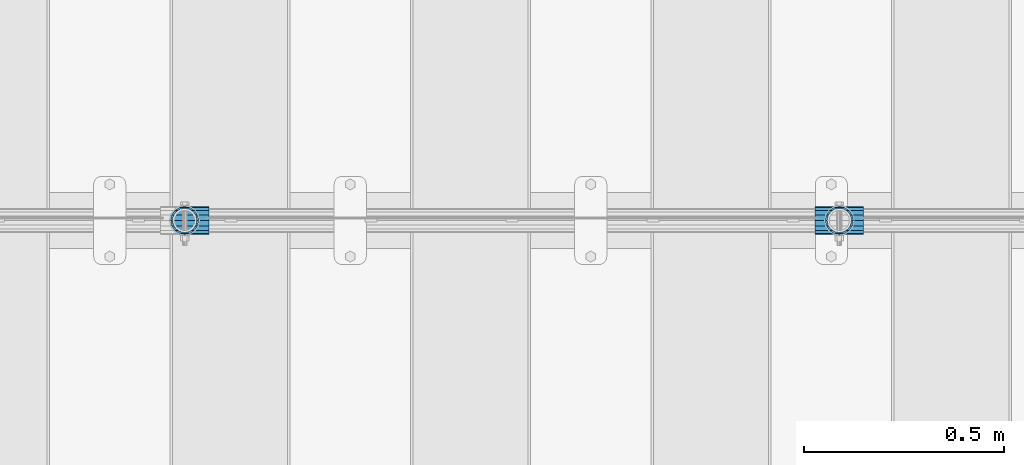
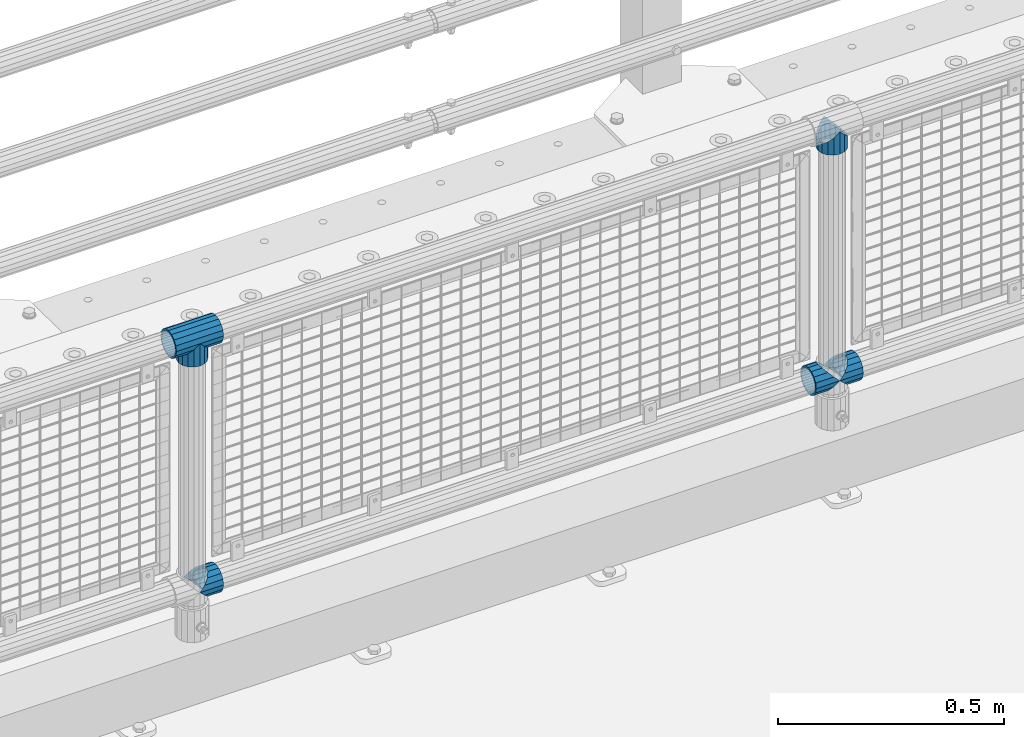
# One storey, part 164 of 270: 6 beams.
"""IFC2X3 building model written with IfcOpenShell, lengths in millimetres."""

from ifc_helpers import new_model, si_unit, frame, origin_with_axes, place, context, subcontext, project, spatial, faceted_brep, material, type_object, element, save


model = new_model("IFC2X3")

# Units and contexts
model_context = context("Model", 3, precision=1e-05, world=origin_with_axes())
body_context = subcontext(model_context, "Body", "Model", "MODEL_VIEW")
ifc_project = project(units=[si_unit("LENGTHUNIT", "METRE", prefix="MILLI"), si_unit("AREAUNIT", "SQUARE_METRE"), si_unit("VOLUMEUNIT", "CUBIC_METRE"), si_unit("MASSUNIT", "GRAM", prefix="KILO"), si_unit("TIMEUNIT", "SECOND"), si_unit("PLANEANGLEUNIT", "RADIAN"), si_unit("SOLIDANGLEUNIT", "STERADIAN"), si_unit("THERMODYNAMICTEMPERATUREUNIT", "DEGREE_CELSIUS"), si_unit("LUMINOUSINTENSITYUNIT", "LUMEN")], contexts=[model_context])

# Site, building, storey
site_placement = place(None, origin_with_axes())
site = spatial("IfcSite", under=ifc_project, at=site_placement, CompositionType="ELEMENT")
building_placement = place(site_placement, origin_with_axes())
building = spatial("IfcBuilding", under=site, at=building_placement, Name="Standard", CompositionType="ELEMENT")
storey_placement = place(building_placement, origin_with_axes())
storey = spatial("IfcBuildingStorey", under=building, at=storey_placement, Name="Undefined", CompositionType="ELEMENT", Elevation=0.0)

# Beams
ifc_material = material(Name="Misc_Undefined")
beam_type = type_object("IfcBeamType", PredefinedType="NOTDEFINED")
beam_1_placement = place(storey_placement, frame((5459.85, -16335.5, 298.17), z_axis=(0.0, 1.0, 0.0), x_axis=(1.0, 0.0, 0.0)))
element("IfcBeam", 1, at=beam_1_placement, inside=storey, type_object=beam_type, material=ifc_material, context=body_context, shape_type="Brep", body=[
    faceted_brep([(60.1499999999978, 0.0, -35.1499999999996), (46.698677352364, 13.4513226476329, -32.4743655677721), (46.698677352364, -13.4513226476329, -32.4743655677721), (33.0273231408937, 21.4606908090117, 21.4606908090118), (27.6756344322275, 26.8123795176776, 13.4513226476338), (27.6756344322275, 32.4743655677717, 13.4513226476338), (35.2951966412911, 24.8548033587072, 24.8548033587067), (35.2951966412911, 16.3810424080045, 24.8548033587067), (27.310256188277, 28.0397438117175, 11.6144421722802), (24.9999999999964, 30.35, 0.0), (24.9999999999964, 35.15, 0.0), (27.6756344322275, 26.8123795176775, -13.4513226476338), (27.6756344322275, 32.4743655677717, -13.4513226476338), (27.310256188277, 28.0397438117175, -11.6144421722802), (35.2951966412911, 16.3810424080045, -24.8548033587067), (35.2951966412911, 24.8548033587072, -24.8548033587067), (33.0273231408937, 21.4606908090117, -21.4606908090118), (40.0617968770166, 11.6144421722805, -28.0397438117179), (43.519339601633, 0.0, -30.3500000000004), (40.0617968770166, -11.6144421722805, -28.0397438117179), (35.2951966412911, -16.3810424080045, -24.8548033587067), (35.2951966412911, -24.8548033587072, -24.8548033587067), (33.0273231408937, -21.4606908090117, -21.4606908090118), (27.6756344322275, -26.8123795176776, -13.4513226476338), (27.6756344322275, -32.4743655677717, -13.4513226476338), (27.310256188277, -28.0397438117175, -11.6144421722802), (24.9999999999964, -30.35, 0.0), (24.9999999999964, -35.15, 0.0), (27.310256188277, -28.0397438117175, 11.6144421722802), (27.6756344322275, -26.8123795176775, 13.4513226476338), (27.6756344322275, -32.4743655677717, 13.4513226476338), (33.0273231408937, -21.4606908090117, 21.4606908090118), (35.2951966412911, -16.3810424080078, 24.8548033587067), (35.2951966412911, -24.8548033587072, 24.8548033587067), (60.1499999999978, 0.0, 35.1499999999996), (46.698677352364, -13.4513226476329, 32.4743655677721), (46.698677352364, 13.4513226476329, 32.4743655677721), (40.061796877013, -11.6144421722805, 28.0397438117179), (43.5193396016293, 0.0, 30.3500000000004), (40.061796877013, 11.6144421722805, 28.0397438117179), (0.0, -32.4743655677721, -13.4513226476338), (0.0, -24.8548033587067, -24.8548033587067), (0.0, -13.4513226476338, -32.4743655677703), (0.0, 0.0, -35.1499999999996), (0.0, 13.4513226476338, -32.4743655677703), (0.0, 24.8548033587067, -24.8548033587067), (0.0, 32.4743655677721, -13.4513226476338), (0.0, 35.1499999999996, 0.0), (0.0, 32.4743655677721, 13.4513226476338), (0.0, 24.8548033587067, 24.8548033587067), (0.0, 13.4513226476338, 32.4743655677703), (0.0, 0.0, 35.1499999999996), (0.0, -32.4743655677721, 13.4513226476338), (0.0, -35.1499999999996, 0.0), (0.0, -24.8548033587067, 24.8548033587067), (0.0, -13.4513226476338, 32.4743655677703), (0.0, -28.0397438117179, -11.614442172282), (0.0, -21.4606908090118, -21.46069080901), (0.0, -11.6144421722802, -28.0397438117179), (0.0, 0.0, -30.3499999999985), (0.0, 11.6144421722802, -28.0397438117179), (0.0, 21.4606908090118, -21.46069080901), (0.0, 28.0397438117179, -11.614442172282), (0.0, 30.3500000000004, 0.0), (0.0, 28.0397438117179, 11.614442172282), (0.0, 21.4606908090118, 21.46069080901), (0.0, 11.6144421722802, 28.0397438117179), (0.0, 0.0, 30.3499999999985), (0.0, -11.6144421722802, 28.0397438117179), (0.0, -21.4606908090118, 21.46069080901), (0.0, -28.0397438117179, 11.614442172282), (0.0, -30.3500000000004, 0.0)], [[[0, 1, 2]], [[3, 4, 5, 6, 7]], [[8, 9, 10, 5, 4]], [[11, 12, 10, 9, 13]], [[14, 15, 12, 11, 16]], [[2, 1, 15, 14, 17, 18, 19, 20, 21]], [[21, 20, 22, 23, 24]], [[24, 23, 25, 26, 27]], [[27, 26, 28, 29, 30]], [[30, 29, 31, 32, 33]], [[34, 35, 36]], [[33, 32, 37, 38, 39, 7, 6, 36, 35]], [[40, 41, 21, 24]], [[41, 42, 2, 21]], [[42, 43, 0, 2]], [[43, 44, 1, 0]], [[44, 45, 15, 1]], [[45, 46, 12, 15]], [[46, 47, 10, 12]], [[47, 48, 5, 10]], [[48, 49, 6, 5]], [[49, 50, 36, 6]], [[50, 51, 34, 36]], [[52, 53, 27, 30]], [[54, 52, 30, 33]], [[55, 54, 33, 35]], [[51, 55, 35, 34]], [[53, 40, 24, 27]], [[52, 54, 55, 51, 50, 49, 48, 47, 46, 45, 44, 43, 42, 41, 40, 53], [56, 57, 58, 59, 60, 61, 62, 63, 64, 65, 66, 67, 68, 69, 70, 71]], [[68, 67, 38, 37]], [[31, 69, 68, 37, 32]], [[28, 70, 69, 31, 29]], [[71, 70, 28, 26]], [[56, 71, 26, 25]], [[57, 56, 25, 23, 22]], [[58, 57, 22, 20, 19]], [[59, 58, 19, 18]], [[60, 59, 18, 17]], [[16, 61, 60, 17, 14]], [[13, 62, 61, 16, 11]], [[63, 62, 13, 9]], [[64, 63, 9, 8]], [[65, 64, 8, 4, 3]], [[66, 65, 3, 7, 39]], [[67, 66, 39, 38]]]),
])
beam_2_placement = place(storey_placement, frame((5520.0, -16335.5, 298.17), z_axis=(0.0, 1.0, 0.0), x_axis=(1.0, 0.0, 0.0)))
element("IfcBeam", 2, at=beam_2_placement, inside=storey, type_object=beam_type, material=ifc_material, context=body_context, shape_type="Brep", body=[
    faceted_brep([(13.4513226476338, 13.4513226476329, 32.4743655677721), (13.4513226476338, -13.4513226476329, 32.4743655677721), (0.0, 0.0, 35.1499999999996), (27.1226768591041, -21.4606908090117, -21.4606908090118), (24.8548033587067, -16.3810424080045, -24.8548033587067), (24.8548033587067, -24.8548033587072, -24.8548033587067), (32.4743655677703, -32.4743655677717, -13.4513226476338), (32.4743655677703, -26.8123795176776, -13.4513226476338), (0.0, 0.0, -35.1499999999996), (13.4513226476338, -13.4513226476329, -32.4743655677721), (13.4513226476338, 13.4513226476329, -32.4743655677721), (20.0882031229849, -11.6144421722805, -28.0397438117179), (16.6306603983721, 0.0, -30.3500000000004), (20.0882031229849, 11.6144421722805, -28.0397438117179), (24.8548033587067, 16.3810424080045, -24.8548033587067), (24.8548033587067, 24.8548033587072, -24.8548033587067), (27.1226768591041, 21.4606908090117, -21.4606908090118), (32.4743655677703, 26.8123795176775, -13.4513226476338), (32.4743655677703, 32.4743655677717, -13.4513226476338), (32.8397438117172, 28.0397438117175, -11.6144421722802), (35.1500000000015, 30.35, 0.0), (35.1500000000015, 35.1500000000003, 0.0), (32.8397438117208, 28.0397438117175, 11.6144421722802), (32.4743655677703, 26.8123795176776, 13.4513226476338), (32.4743655677703, 32.4743655677717, 13.4513226476338), (27.1226768591041, 21.4606908090117, 21.4606908090118), (24.8548033587067, 16.3810424080045, 24.8548033587067), (24.8548033587067, 24.8548033587072, 24.8548033587067), (20.0882031229812, 11.6144421722805, 28.0397438117179), (16.6306603983612, 0.0, 30.3500000000004), (20.0882031229812, -11.6144421722805, 28.0397438117179), (24.8548033587067, -16.3810424080045, 24.8548033587067), (24.8548033587067, -24.8548033587072, 24.8548033587067), (32.4743655677703, -26.8123795176775, 13.4513226476338), (32.4743655677703, -32.4743655677717, 13.4513226476338), (27.1226768591041, -21.4606908090117, 21.4606908090118), (35.1500000000015, -30.35, 0.0), (35.1500000000015, -35.15, 0.0), (32.8397438117208, -28.0397438117175, 11.6144421722802), (32.8397438117172, -28.0397438117175, -11.6144421722802), (60.1500000000015, -24.8548033587072, -24.8548033587067), (60.1500000000015, -32.4743655677717, -13.4513226476338), (60.1500000000015, -13.4513226476329, -32.4743655677721), (60.1499999999978, 0.0, -35.1499999999996), (60.1500000000015, 13.4513226476329, -32.4743655677721), (60.1500000000015, 24.8548033587072, -24.8548033587067), (60.1500000000015, 32.4743655677717, -13.4513226476338), (60.1500000000015, 35.15, 0.0), (60.1500000000015, 32.4743655677717, 13.4513226476338), (60.1500000000015, 24.8548033587072, 24.8548033587067), (60.1500000000015, 13.4513226476329, 32.4743655677721), (60.1499999999978, 0.0, 35.1499999999996), (60.1500000000015, -13.4513226476329, 32.4743655677721), (60.1500000000015, -24.8548033587072, 24.8548033587067), (60.1500000000015, -32.4743655677717, 13.4513226476338), (60.1500000000015, -35.15, 0.0), (60.1500000000015, -21.4606908090117, 21.4606908090118), (60.1500000000015, -11.6144421722805, 28.0397438117179), (60.1500000000015, 0.0, 30.3500000000004), (60.1500000000015, 11.6144421722805, 28.0397438117179), (60.1500000000015, 21.4606908090117, 21.4606908090118), (60.1500000000015, 28.0397438117175, 11.6144421722802), (60.1500000000015, 30.35, 0.0), (60.1500000000015, 28.0397438117175, -11.6144421722802), (60.1500000000015, 21.4606908090117, -21.4606908090118), (60.1500000000015, 11.6144421722805, -28.0397438117179), (60.1500000000015, 0.0, -30.3500000000004), (60.1500000000015, -11.6144421722805, -28.0397438117179), (60.1500000000015, -21.4606908090117, -21.4606908090118), (60.1500000000015, -28.0397438117175, -11.6144421722802), (60.1500000000015, -30.35, 0.0), (60.1500000000015, -28.0397438117175, 11.6144421722802)], [[[0, 1, 2]], [[3, 4, 5, 6, 7]], [[8, 9, 10]], [[10, 9, 5, 4, 11, 12, 13, 14, 15]], [[15, 14, 16, 17, 18]], [[18, 17, 19, 20, 21]], [[21, 20, 22, 23, 24]], [[24, 23, 25, 26, 27]], [[27, 26, 28, 29, 30, 31, 32, 1, 0]], [[33, 34, 32, 31, 35]], [[36, 37, 34, 33, 38]], [[39, 7, 6, 37, 36]], [[40, 41, 6, 5]], [[42, 40, 5, 9]], [[43, 42, 9, 8]], [[44, 43, 8, 10]], [[45, 44, 10, 15]], [[46, 45, 15, 18]], [[47, 46, 18, 21]], [[48, 47, 21, 24]], [[49, 48, 24, 27]], [[50, 49, 27, 0]], [[51, 50, 0, 2]], [[52, 51, 2, 1]], [[53, 52, 1, 32]], [[54, 53, 32, 34]], [[55, 54, 34, 37]], [[41, 55, 37, 6]], [[40, 42, 43, 44, 45, 46, 47, 48, 49, 50, 51, 52, 53, 54, 55, 41], [56, 57, 58, 59, 60, 61, 62, 63, 64, 65, 66, 67, 68, 69, 70, 71]], [[71, 70, 36, 38]], [[35, 56, 71, 38, 33]], [[30, 57, 56, 35, 31]], [[58, 57, 30, 29]], [[59, 58, 29, 28]], [[60, 59, 28, 26, 25]], [[61, 60, 25, 23, 22]], [[62, 61, 22, 20]], [[63, 62, 20, 19]], [[16, 64, 63, 19, 17]], [[13, 65, 64, 16, 14]], [[66, 65, 13, 12]], [[67, 66, 12, 11]], [[68, 67, 11, 4, 3]], [[69, 68, 3, 7, 39]], [[70, 69, 39, 36]]]),
])
beam_3_placement = place(storey_placement, frame((3887.0, -16335.5, 298.17), z_axis=(0.0, 1.0, 0.0), x_axis=(1.0, 0.0, 0.0)))
element("IfcBeam", 3, at=beam_3_placement, inside=storey, type_object=beam_type, material=ifc_material, context=body_context, shape_type="Brep", body=[
    faceted_brep([(13.4513226476338, 13.4513226476329, 32.4743655677721), (13.4513226476338, -13.4513226476329, 32.4743655677721), (0.0, 0.0, 35.1499999999996), (27.1226768591041, -21.4606908090117, -21.4606908090118), (24.8548033587067, -16.3810424080045, -24.8548033587067), (24.8548033587067, -24.8548033587072, -24.8548033587067), (32.4743655677703, -32.4743655677717, -13.4513226476338), (32.4743655677703, -26.8123795176776, -13.4513226476338), (0.0, 0.0, -35.1499999999996), (13.4513226476338, -13.4513226476329, -32.4743655677721), (13.4513226476338, 13.4513226476329, -32.4743655677721), (20.0882031229849, -11.6144421722805, -28.0397438117179), (16.6306603983721, 0.0, -30.3500000000004), (20.0882031229849, 11.6144421722805, -28.0397438117179), (24.8548033587067, 16.3810424080045, -24.8548033587067), (24.8548033587067, 24.8548033587072, -24.8548033587067), (27.1226768591041, 21.4606908090117, -21.4606908090118), (32.4743655677703, 26.8123795176775, -13.4513226476338), (32.4743655677703, 32.4743655677717, -13.4513226476338), (32.8397438117172, 28.0397438117175, -11.6144421722802), (35.1500000000015, 30.35, 0.0), (35.1500000000015, 35.1500000000003, 0.0), (32.8397438117208, 28.0397438117175, 11.6144421722802), (32.4743655677703, 26.8123795176776, 13.4513226476338), (32.4743655677703, 32.4743655677717, 13.4513226476338), (27.1226768591041, 21.4606908090117, 21.4606908090118), (24.8548033587067, 16.3810424080045, 24.8548033587067), (24.8548033587067, 24.8548033587072, 24.8548033587067), (20.0882031229812, 11.6144421722805, 28.0397438117179), (16.6306603983612, 0.0, 30.3500000000004), (20.0882031229812, -11.6144421722805, 28.0397438117179), (24.8548033587067, -16.3810424080045, 24.8548033587067), (24.8548033587067, -24.8548033587072, 24.8548033587067), (32.4743655677703, -26.8123795176775, 13.4513226476338), (32.4743655677703, -32.4743655677717, 13.4513226476338), (27.1226768591041, -21.4606908090117, 21.4606908090118), (35.1500000000015, -30.35, 0.0), (35.1500000000015, -35.15, 0.0), (32.8397438117208, -28.0397438117175, 11.6144421722802), (32.8397438117172, -28.0397438117175, -11.6144421722802), (60.1500000000015, -24.8548033587072, -24.8548033587067), (60.1500000000015, -32.4743655677717, -13.4513226476338), (60.1500000000015, -13.4513226476329, -32.4743655677721), (60.1499999999978, 0.0, -35.1499999999996), (60.1500000000015, 13.4513226476329, -32.4743655677721), (60.1500000000015, 24.8548033587072, -24.8548033587067), (60.1500000000015, 32.4743655677717, -13.4513226476338), (60.1500000000015, 35.15, 0.0), (60.1500000000015, 32.4743655677717, 13.4513226476338), (60.1500000000015, 24.8548033587072, 24.8548033587067), (60.1500000000015, 13.4513226476329, 32.4743655677721), (60.1499999999978, 0.0, 35.1499999999996), (60.1500000000015, -13.4513226476329, 32.4743655677721), (60.1500000000015, -24.8548033587072, 24.8548033587067), (60.1500000000015, -32.4743655677717, 13.4513226476338), (60.1500000000015, -35.15, 0.0), (60.1500000000015, -21.4606908090117, 21.4606908090118), (60.1500000000015, -11.6144421722805, 28.0397438117179), (60.1500000000015, 0.0, 30.3500000000004), (60.1500000000015, 11.6144421722805, 28.0397438117179), (60.1500000000015, 21.4606908090117, 21.4606908090118), (60.1500000000015, 28.0397438117175, 11.6144421722802), (60.1500000000015, 30.35, 0.0), (60.1500000000015, 28.0397438117175, -11.6144421722802), (60.1500000000015, 21.4606908090117, -21.4606908090118), (60.1500000000015, 11.6144421722805, -28.0397438117179), (60.1500000000015, 0.0, -30.3500000000004), (60.1500000000015, -11.6144421722805, -28.0397438117179), (60.1500000000015, -21.4606908090117, -21.4606908090118), (60.1500000000015, -28.0397438117175, -11.6144421722802), (60.1500000000015, -30.35, 0.0), (60.1500000000015, -28.0397438117175, 11.6144421722802)], [[[0, 1, 2]], [[3, 4, 5, 6, 7]], [[8, 9, 10]], [[10, 9, 5, 4, 11, 12, 13, 14, 15]], [[15, 14, 16, 17, 18]], [[18, 17, 19, 20, 21]], [[21, 20, 22, 23, 24]], [[24, 23, 25, 26, 27]], [[27, 26, 28, 29, 30, 31, 32, 1, 0]], [[33, 34, 32, 31, 35]], [[36, 37, 34, 33, 38]], [[39, 7, 6, 37, 36]], [[40, 41, 6, 5]], [[42, 40, 5, 9]], [[43, 42, 9, 8]], [[44, 43, 8, 10]], [[45, 44, 10, 15]], [[46, 45, 15, 18]], [[47, 46, 18, 21]], [[48, 47, 21, 24]], [[49, 48, 24, 27]], [[50, 49, 27, 0]], [[51, 50, 0, 2]], [[52, 51, 2, 1]], [[53, 52, 1, 32]], [[54, 53, 32, 34]], [[55, 54, 34, 37]], [[41, 55, 37, 6]], [[40, 42, 43, 44, 45, 46, 47, 48, 49, 50, 51, 52, 53, 54, 55, 41], [56, 57, 58, 59, 60, 61, 62, 63, 64, 65, 66, 67, 68, 69, 70, 71]], [[71, 70, 36, 38]], [[35, 56, 71, 38, 33]], [[30, 57, 56, 35, 31]], [[58, 57, 30, 29]], [[59, 58, 29, 28]], [[60, 59, 28, 26, 25]], [[61, 60, 25, 23, 22]], [[62, 61, 22, 20]], [[63, 62, 20, 19]], [[16, 64, 63, 19, 17]], [[13, 65, 64, 16, 14]], [[66, 65, 13, 12]], [[67, 66, 12, 11]], [[68, 67, 11, 4, 3]], [[69, 68, 3, 7, 39]], [[70, 69, 39, 36]]]),
])
beam_4_placement = place(storey_placement, frame((5520.0, -16335.5, 969.849999999999), z_axis=(0.0, 1.0, 0.0), x_axis=(0.0, 0.0, -1.0)))
element("IfcBeam", 4, at=beam_4_placement, inside=storey, type_object=beam_type, material=ifc_material, context=body_context, shape_type="Brep", body=[
    faceted_brep([(13.4513226476338, 13.4513226476329, 32.4743655677721), (13.4513226476338, -13.4513226476329, 32.4743655677721), (0.0, 0.0, 35.1499999999996), (27.1226768591041, -21.4606908090117, -21.4606908090118), (24.8548033587067, -16.3810424080045, -24.8548033587067), (24.8548033587067, -24.8548033587072, -24.8548033587067), (32.4743655677703, -32.4743655677717, -13.4513226476338), (32.4743655677703, -26.8123795176776, -13.4513226476338), (0.0, 0.0, -35.1499999999996), (13.4513226476338, -13.4513226476329, -32.4743655677721), (13.4513226476338, 13.4513226476329, -32.4743655677721), (20.0882031229849, -11.6144421722805, -28.0397438117179), (16.6306603983721, 0.0, -30.3500000000004), (20.0882031229849, 11.6144421722805, -28.0397438117179), (24.8548033587067, 16.3810424080045, -24.8548033587067), (24.8548033587067, 24.8548033587072, -24.8548033587067), (27.1226768591041, 21.4606908090117, -21.4606908090118), (32.4743655677703, 26.8123795176775, -13.4513226476338), (32.4743655677703, 32.4743655677717, -13.4513226476338), (32.8397438117172, 28.0397438117175, -11.6144421722802), (35.1500000000015, 30.35, 0.0), (35.1500000000015, 35.1500000000003, 0.0), (32.8397438117208, 28.0397438117175, 11.6144421722802), (32.4743655677703, 26.8123795176776, 13.4513226476338), (32.4743655677703, 32.4743655677717, 13.4513226476338), (27.1226768591041, 21.4606908090117, 21.4606908090118), (24.8548033587067, 16.3810424080045, 24.8548033587067), (24.8548033587067, 24.8548033587072, 24.8548033587067), (20.0882031229812, 11.6144421722805, 28.0397438117179), (16.6306603983612, 0.0, 30.3500000000004), (20.0882031229812, -11.6144421722805, 28.0397438117179), (24.8548033587067, -16.3810424080045, 24.8548033587067), (24.8548033587067, -24.8548033587072, 24.8548033587067), (32.4743655677703, -26.8123795176775, 13.4513226476338), (32.4743655677703, -32.4743655677717, 13.4513226476338), (27.1226768591041, -21.4606908090117, 21.4606908090118), (35.1500000000015, -30.35, 0.0), (35.1500000000015, -35.15, 0.0), (32.8397438117208, -28.0397438117175, 11.6144421722802), (32.8397438117172, -28.0397438117175, -11.6144421722802), (60.1500000000015, -24.8548033587072, -24.8548033587067), (60.1500000000015, -32.4743655677717, -13.4513226476338), (60.1500000000015, -13.4513226476329, -32.4743655677721), (60.1499999999978, 0.0, -35.1499999999996), (60.1500000000015, 13.4513226476329, -32.4743655677721), (60.1500000000015, 24.8548033587072, -24.8548033587067), (60.1500000000015, 32.4743655677717, -13.4513226476338), (60.1500000000015, 35.15, 0.0), (60.1500000000015, 32.4743655677717, 13.4513226476338), (60.1500000000015, 24.8548033587072, 24.8548033587067), (60.1500000000015, 13.4513226476329, 32.4743655677721), (60.1499999999978, 0.0, 35.1499999999996), (60.1500000000015, -13.4513226476329, 32.4743655677721), (60.1500000000015, -24.8548033587072, 24.8548033587067), (60.1500000000015, -32.4743655677717, 13.4513226476338), (60.1500000000015, -35.15, 0.0), (60.1500000000015, -21.4606908090117, 21.4606908090118), (60.1500000000015, -11.6144421722805, 28.0397438117179), (60.1500000000015, 0.0, 30.3500000000004), (60.1500000000015, 11.6144421722805, 28.0397438117179), (60.1500000000015, 21.4606908090117, 21.4606908090118), (60.1500000000015, 28.0397438117175, 11.6144421722802), (60.1500000000015, 30.35, 0.0), (60.1500000000015, 28.0397438117175, -11.6144421722802), (60.1500000000015, 21.4606908090117, -21.4606908090118), (60.1500000000015, 11.6144421722805, -28.0397438117179), (60.1500000000015, 0.0, -30.3500000000004), (60.1500000000015, -11.6144421722805, -28.0397438117179), (60.1500000000015, -21.4606908090117, -21.4606908090118), (60.1500000000015, -28.0397438117175, -11.6144421722802), (60.1500000000015, -30.35, 0.0), (60.1500000000015, -28.0397438117175, 11.6144421722802)], [[[0, 1, 2]], [[3, 4, 5, 6, 7]], [[8, 9, 10]], [[10, 9, 5, 4, 11, 12, 13, 14, 15]], [[15, 14, 16, 17, 18]], [[18, 17, 19, 20, 21]], [[21, 20, 22, 23, 24]], [[24, 23, 25, 26, 27]], [[27, 26, 28, 29, 30, 31, 32, 1, 0]], [[33, 34, 32, 31, 35]], [[36, 37, 34, 33, 38]], [[39, 7, 6, 37, 36]], [[40, 41, 6, 5]], [[42, 40, 5, 9]], [[43, 42, 9, 8]], [[44, 43, 8, 10]], [[45, 44, 10, 15]], [[46, 45, 15, 18]], [[47, 46, 18, 21]], [[48, 47, 21, 24]], [[49, 48, 24, 27]], [[50, 49, 27, 0]], [[51, 50, 0, 2]], [[52, 51, 2, 1]], [[53, 52, 1, 32]], [[54, 53, 32, 34]], [[55, 54, 34, 37]], [[41, 55, 37, 6]], [[40, 42, 43, 44, 45, 46, 47, 48, 49, 50, 51, 52, 53, 54, 55, 41], [56, 57, 58, 59, 60, 61, 62, 63, 64, 65, 66, 67, 68, 69, 70, 71]], [[71, 70, 36, 38]], [[35, 56, 71, 38, 33]], [[30, 57, 56, 35, 31]], [[58, 57, 30, 29]], [[59, 58, 29, 28]], [[60, 59, 28, 26, 25]], [[61, 60, 25, 23, 22]], [[62, 61, 22, 20]], [[63, 62, 20, 19]], [[16, 64, 63, 19, 17]], [[13, 65, 64, 16, 14]], [[66, 65, 13, 12]], [[67, 66, 12, 11]], [[68, 67, 11, 4, 3]], [[69, 68, 3, 7, 39]], [[70, 69, 39, 36]]]),
])
beam_5_placement = place(storey_placement, frame((3887.0, -16335.5, 969.849999999999), z_axis=(0.0, 1.0, 0.0), x_axis=(0.0, 0.0, -1.0)))
element("IfcBeam", 5, at=beam_5_placement, inside=storey, type_object=beam_type, material=ifc_material, context=body_context, shape_type="Brep", body=[
    faceted_brep([(13.4513226476338, 13.4513226476329, 32.4743655677721), (13.4513226476338, -13.4513226476329, 32.4743655677721), (0.0, 0.0, 35.1499999999996), (27.1226768591041, -21.4606908090117, -21.4606908090118), (24.8548033587067, -16.3810424080045, -24.8548033587067), (24.8548033587067, -24.8548033587072, -24.8548033587067), (32.4743655677703, -32.4743655677717, -13.4513226476338), (32.4743655677703, -26.8123795176776, -13.4513226476338), (0.0, 0.0, -35.1499999999996), (13.4513226476338, -13.4513226476329, -32.4743655677721), (13.4513226476338, 13.4513226476329, -32.4743655677721), (20.0882031229849, -11.6144421722805, -28.0397438117179), (16.6306603983721, 0.0, -30.3500000000004), (20.0882031229849, 11.6144421722805, -28.0397438117179), (24.8548033587067, 16.3810424080045, -24.8548033587067), (24.8548033587067, 24.8548033587072, -24.8548033587067), (27.1226768591041, 21.4606908090117, -21.4606908090118), (32.4743655677703, 26.8123795176775, -13.4513226476338), (32.4743655677703, 32.4743655677717, -13.4513226476338), (32.8397438117172, 28.0397438117175, -11.6144421722802), (35.1500000000015, 30.35, 0.0), (35.1500000000015, 35.1500000000003, 0.0), (32.8397438117208, 28.0397438117175, 11.6144421722802), (32.4743655677703, 26.8123795176776, 13.4513226476338), (32.4743655677703, 32.4743655677717, 13.4513226476338), (27.1226768591041, 21.4606908090117, 21.4606908090118), (24.8548033587067, 16.3810424080045, 24.8548033587067), (24.8548033587067, 24.8548033587072, 24.8548033587067), (20.0882031229812, 11.6144421722805, 28.0397438117179), (16.6306603983612, 0.0, 30.3500000000004), (20.0882031229812, -11.6144421722805, 28.0397438117179), (24.8548033587067, -16.3810424080045, 24.8548033587067), (24.8548033587067, -24.8548033587072, 24.8548033587067), (32.4743655677703, -26.8123795176775, 13.4513226476338), (32.4743655677703, -32.4743655677717, 13.4513226476338), (27.1226768591041, -21.4606908090117, 21.4606908090118), (35.1500000000015, -30.35, 0.0), (35.1500000000015, -35.15, 0.0), (32.8397438117208, -28.0397438117175, 11.6144421722802), (32.8397438117172, -28.0397438117175, -11.6144421722802), (60.1500000000015, -24.8548033587072, -24.8548033587067), (60.1500000000015, -32.4743655677717, -13.4513226476338), (60.1500000000015, -13.4513226476329, -32.4743655677721), (60.1499999999978, 0.0, -35.1499999999996), (60.1500000000015, 13.4513226476329, -32.4743655677721), (60.1500000000015, 24.8548033587072, -24.8548033587067), (60.1500000000015, 32.4743655677717, -13.4513226476338), (60.1500000000015, 35.15, 0.0), (60.1500000000015, 32.4743655677717, 13.4513226476338), (60.1500000000015, 24.8548033587072, 24.8548033587067), (60.1500000000015, 13.4513226476329, 32.4743655677721), (60.1499999999978, 0.0, 35.1499999999996), (60.1500000000015, -13.4513226476329, 32.4743655677721), (60.1500000000015, -24.8548033587072, 24.8548033587067), (60.1500000000015, -32.4743655677717, 13.4513226476338), (60.1500000000015, -35.15, 0.0), (60.1500000000015, -21.4606908090117, 21.4606908090118), (60.1500000000015, -11.6144421722805, 28.0397438117179), (60.1500000000015, 0.0, 30.3500000000004), (60.1500000000015, 11.6144421722805, 28.0397438117179), (60.1500000000015, 21.4606908090117, 21.4606908090118), (60.1500000000015, 28.0397438117175, 11.6144421722802), (60.1500000000015, 30.35, 0.0), (60.1500000000015, 28.0397438117175, -11.6144421722802), (60.1500000000015, 21.4606908090117, -21.4606908090118), (60.1500000000015, 11.6144421722805, -28.0397438117179), (60.1500000000015, 0.0, -30.3500000000004), (60.1500000000015, -11.6144421722805, -28.0397438117179), (60.1500000000015, -21.4606908090117, -21.4606908090118), (60.1500000000015, -28.0397438117175, -11.6144421722802), (60.1500000000015, -30.35, 0.0), (60.1500000000015, -28.0397438117175, 11.6144421722802)], [[[0, 1, 2]], [[3, 4, 5, 6, 7]], [[8, 9, 10]], [[10, 9, 5, 4, 11, 12, 13, 14, 15]], [[15, 14, 16, 17, 18]], [[18, 17, 19, 20, 21]], [[21, 20, 22, 23, 24]], [[24, 23, 25, 26, 27]], [[27, 26, 28, 29, 30, 31, 32, 1, 0]], [[33, 34, 32, 31, 35]], [[36, 37, 34, 33, 38]], [[39, 7, 6, 37, 36]], [[40, 41, 6, 5]], [[42, 40, 5, 9]], [[43, 42, 9, 8]], [[44, 43, 8, 10]], [[45, 44, 10, 15]], [[46, 45, 15, 18]], [[47, 46, 18, 21]], [[48, 47, 21, 24]], [[49, 48, 24, 27]], [[50, 49, 27, 0]], [[51, 50, 0, 2]], [[52, 51, 2, 1]], [[53, 52, 1, 32]], [[54, 53, 32, 34]], [[55, 54, 34, 37]], [[41, 55, 37, 6]], [[40, 42, 43, 44, 45, 46, 47, 48, 49, 50, 51, 52, 53, 54, 55, 41], [56, 57, 58, 59, 60, 61, 62, 63, 64, 65, 66, 67, 68, 69, 70, 71]], [[71, 70, 36, 38]], [[35, 56, 71, 38, 33]], [[30, 57, 56, 35, 31]], [[58, 57, 30, 29]], [[59, 58, 29, 28]], [[60, 59, 28, 26, 25]], [[61, 60, 25, 23, 22]], [[62, 61, 22, 20]], [[63, 62, 20, 19]], [[16, 64, 63, 19, 17]], [[13, 65, 64, 16, 14]], [[66, 65, 13, 12]], [[67, 66, 12, 11]], [[68, 67, 11, 4, 3]], [[69, 68, 3, 7, 39]], [[70, 69, 39, 36]]]),
])
beam_6_placement = place(storey_placement, frame((3826.85, -16335.5, 969.849999999999), z_axis=(0.0, 0.0, 1.0), x_axis=(1.0, 0.0, 0.0)))
element("IfcBeam", 6, at=beam_6_placement, inside=storey, type_object=beam_type, material=ifc_material, context=body_context, shape_type="Brep", body=[
    faceted_brep([(88.1897438117176, -11.6144421722802, -28.0397438117176), (88.1897438117176, -11.6144421722802, -32.839743811718), (86.9623795176758, -13.4513226476338, -32.4743655677718), (81.6106908090119, -21.4606908090118, -27.1226768591079), (81.6106908090119, -21.4606908090118, -21.4606908090117), (76.5310424080044, -24.8548033587067, -24.8548033587072), (71.7644421722807, -28.0397438117179, -20.0882031229829), (71.7644421722807, -28.0397438117179, -11.6144421722805), (60.1500000000001, -30.3500000000004, -16.6306603983638), (60.1500000000015, -30.35, 0.0), (48.5355578277195, -28.0397438117179, -20.0882031229829), (48.5355578277195, -28.0397438117179, -11.6144421722805), (43.7689575919958, -24.8548033587067, -24.8548033587072), (38.6893091909883, -21.4606908090118, -27.1226768591079), (38.6893091909883, -21.4606908090118, -21.4606908090117), (33.3376204823235, -13.4513226476338, -32.4743655677718), (32.1102561882826, -11.6144421722802, -32.839743811718), (32.1102561882826, -11.6144421722802, -28.0397438117176), (29.8000000000002, 0.0, -35.15), (29.8000000000002, 0.0, -30.35), (32.1102561882826, 11.6144421722802, -32.839743811718), (32.1102561882826, 11.6144421722802, -28.0397438117176), (33.3376204823244, 13.4513226476338, -32.4743655677718), (38.6893091909883, 21.4606908090118, -27.1226768591056), (38.6893091909883, 21.4606908090118, -21.4606908090117), (43.7689575919958, 24.8548033587067, -24.8548033587072), (48.5355578277195, 28.0397438117179, -20.0882031229829), (48.5355578277195, 28.0397438117179, -11.6144421722805), (60.1500000000001, 30.3500000000004, -16.6306603983638), (60.1500000000015, 30.35, 0.0), (71.7644421722807, 28.0397438117179, -20.0882031229829), (71.7644421722807, 28.0397438117179, -11.6144421722805), (76.5310424080044, 24.8548033587067, -24.8548033587072), (81.6106908090119, 21.4606908090118, -27.1226768591056), (81.6106908090119, 21.4606908090118, -21.4606908090117), (86.9623795176776, 13.4513226476338, -32.4743655677718), (88.1897438117176, 11.6144421722802, -32.839743811718), (88.1897438117176, 11.6144421722802, -28.0397438117176), (90.5, 0.0, -35.15), (90.5, 0.0, -30.35), (0.0, -21.4606908090118, -21.46069080901), (0.0, -28.0397438117179, -11.614442172282), (0.0, -11.6144421722802, -28.0397438117179), (0.0, 0.0, -30.3499999999985), (0.0, 11.6144421722802, -28.0397438117179), (0.0, 21.4606908090118, -21.46069080901), (0.0, 28.0397438117179, -11.614442172282), (0.0, 30.3500000000004, 0.0), (0.0, 32.4743655677721, -13.4513226476338), (0.0, 35.1499999999996, 0.0), (120.3, 35.1499999999996, 0.0), (120.3, 32.4743655677721, -13.4513226476329), (0.0, 32.4743655677721, 13.4513226476338), (120.3, 32.4743655677721, 13.4513226476329), (0.0, 24.8548033587067, 24.8548033587067), (120.3, 24.8548033587067, 24.8548033587072), (0.0, 13.4513226476338, 32.4743655677703), (120.3, 13.4513226476338, 32.4743655677718), (0.0, 0.0, 35.1499999999996), (120.3, 0.0, 35.15), (0.0, -13.4513226476338, 32.4743655677703), (120.3, -13.4513226476338, 32.4743655677718), (0.0, -24.8548033587067, 24.8548033587067), (120.3, -24.8548033587067, 24.8548033587072), (0.0, -32.4743655677721, 13.4513226476338), (120.3, -32.4743655677721, 13.4513226476329), (0.0, -35.1499999999996, 0.0), (120.3, -35.1499999999996, 0.0), (0.0, -32.4743655677721, -13.4513226476338), (120.3, -32.4743655677721, -13.4513226476329), (0.0, 24.8548033587067, -24.8548033587067), (0.0, 13.4513226476338, -32.4743655677703), (0.0, 0.0, -35.1499999999996), (0.0, -13.4513226476338, -32.4743655677703), (0.0, -24.8548033587067, -24.8548033587067), (0.0, 28.0397438117179, 11.614442172282), (0.0, 21.4606908090118, 21.46069080901), (0.0, 11.6144421722802, 28.0397438117179), (0.0, 0.0, 30.3499999999985), (0.0, -11.6144421722802, 28.0397438117179), (0.0, -21.4606908090118, 21.46069080901), (0.0, -28.0397438117179, 11.614442172282), (0.0, -30.3500000000004, 0.0), (120.3, -30.3500000000004, 0.0), (120.3, -28.0397438117179, -11.6144421722805), (120.3, -21.4606908090118, -21.4606908090117), (120.3, -11.6144421722802, -28.0397438117176), (120.3, 0.0, -30.35), (120.3, 21.4606908090118, -21.4606908090117), (120.3, 28.0397438117179, -11.6144421722805), (120.3, 11.6144421722802, -28.0397438117176), (120.3, 30.3500000000004, 0.0), (120.3, 28.0397438117179, 11.6144421722805), (120.3, 21.4606908090118, 21.4606908090117), (120.3, 11.6144421722802, 28.0397438117176), (120.3, 0.0, 30.35), (120.3, -11.6144421722802, 28.0397438117176), (120.3, -21.4606908090118, 21.4606908090117), (120.3, -28.0397438117179, 11.6144421722805), (120.3, -24.8548033587067, -24.8548033587072), (120.3, -13.4513226476338, -32.4743655677718), (120.3, 0.0, -35.15), (120.3, 13.4513226476338, -32.4743655677718), (120.3, 24.8548033587067, -24.8548033587072)], [[[0, 1, 2, 3, 4]], [[4, 3, 5, 6, 7]], [[7, 6, 8, 9]], [[9, 8, 10, 11]], [[11, 10, 12, 13, 14]], [[14, 13, 15, 16, 17]], [[17, 16, 18, 19]], [[19, 18, 20, 21]], [[21, 20, 22, 23, 24]], [[24, 23, 25, 26, 27]], [[27, 26, 28, 29]], [[29, 28, 30, 31]], [[31, 30, 32, 33, 34]], [[34, 33, 35, 36, 37]], [[37, 36, 38, 39]], [[39, 38, 1, 0]], [[40, 41, 11, 14]], [[42, 40, 14, 17]], [[43, 42, 17, 19]], [[44, 43, 19, 21]], [[45, 44, 21, 24]], [[46, 45, 24, 27]], [[47, 46, 27, 29]], [[48, 49, 50, 51]], [[49, 52, 53, 50]], [[52, 54, 55, 53]], [[54, 56, 57, 55]], [[56, 58, 59, 57]], [[58, 60, 61, 59]], [[60, 62, 63, 61]], [[62, 64, 65, 63]], [[64, 66, 67, 65]], [[66, 68, 69, 67]], [[64, 62, 60, 58, 56, 54, 52, 49, 48, 70, 71, 72, 73, 74, 68, 66], [41, 40, 42, 43, 44, 45, 46, 47, 75, 76, 77, 78, 79, 80, 81, 82]], [[41, 82, 9, 11]], [[83, 84, 7, 9]], [[84, 85, 4, 7]], [[85, 86, 0, 4]], [[86, 87, 39, 0]], [[88, 89, 31, 34]], [[90, 88, 34, 37]], [[87, 90, 37, 39]], [[89, 91, 29, 31]], [[75, 47, 29, 91, 92]], [[76, 75, 92, 93]], [[77, 76, 93, 94]], [[78, 77, 94, 95]], [[79, 78, 95, 96]], [[80, 79, 96, 97]], [[81, 80, 97, 98]], [[9, 82, 81, 98, 83]], [[99, 100, 101, 102, 103, 51, 50, 53, 55, 57, 59, 61, 63, 65, 67, 69], [97, 96, 95, 94, 93, 92, 91, 89, 88, 90, 87, 86, 85, 84, 83, 98]], [[35, 102, 101, 38, 36]], [[32, 103, 102, 35, 33]], [[28, 26, 25, 70, 48, 51, 103, 32, 30]], [[22, 71, 70, 25, 23]], [[18, 72, 71, 22, 20]], [[73, 72, 18, 16, 15]], [[74, 73, 15, 13, 12]], [[99, 69, 68, 74, 12, 10, 8, 6, 5]], [[100, 99, 5, 3, 2]], [[101, 100, 2, 1, 38]]]),
])

save(model, "model.ifc")
